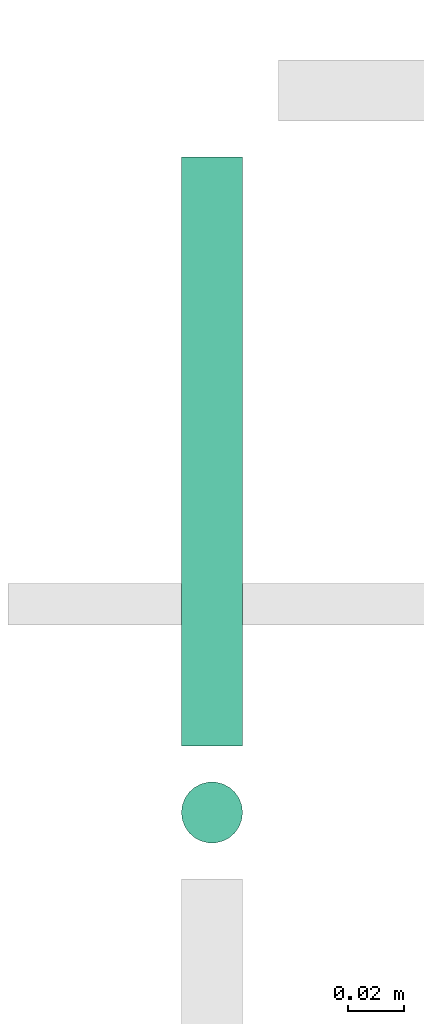
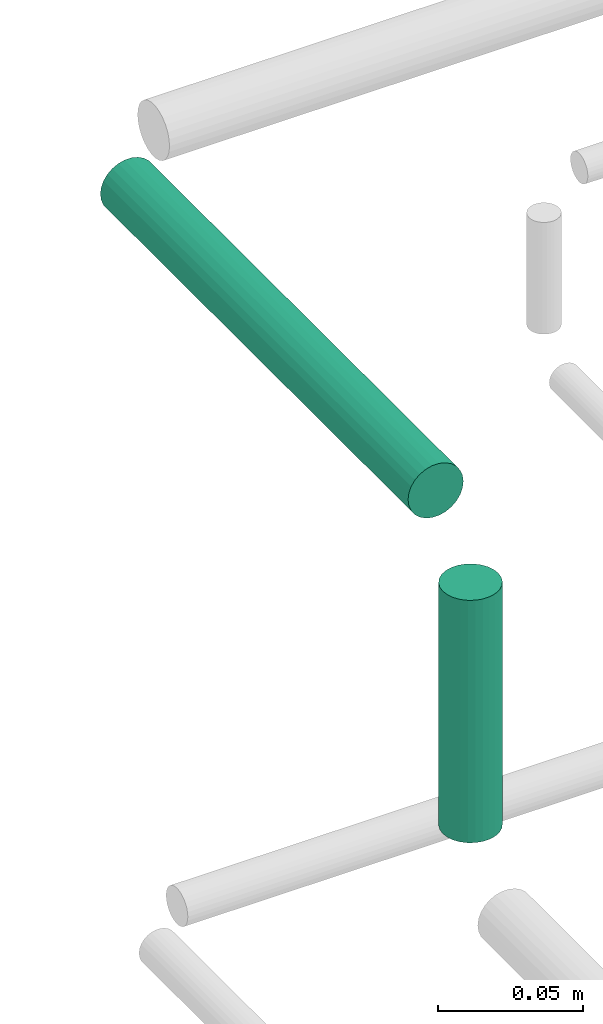
# One storey, part 126 of 331: 2 flow segments.
"""IFC2X3 building model written with IfcOpenShell, lengths in millimetres."""

from ifc_helpers import new_model, entity, si_unit, converted_unit, derived_unit, direction, frame, origin, origin_2d_with_axis, place, context, subcontext, project, spatial, circle, extrude, type_object, element, save


model = new_model("IFC2X3")

# Units and contexts
model_context = context("Model", 3, precision=0.01, world=origin(), true_north=direction((6.12303176911189e-17, 1.0)))
body_context = subcontext(model_context, "Body", "Model", "MODEL_VIEW")
ifc_project = project(units=[si_unit("LENGTHUNIT", "METRE", prefix="MILLI"), si_unit("AREAUNIT", "SQUARE_METRE"), si_unit("VOLUMEUNIT", "CUBIC_METRE"), converted_unit("PLANEANGLEUNIT", "DEGREE", entity("IfcRatioMeasure", 0.0174532925199433), si_unit("PLANEANGLEUNIT", "RADIAN"), dimensions=[0, 0, 0, 0, 0, 0, 0]), si_unit("MASSUNIT", "GRAM", prefix="KILO"), derived_unit("MASSDENSITYUNIT", [(si_unit("MASSUNIT", "GRAM", prefix="KILO"), 1), (si_unit("LENGTHUNIT", "METRE"), -3)]), derived_unit("MOMENTOFINERTIAUNIT", [(si_unit("LENGTHUNIT", "METRE"), 4)]), si_unit("TIMEUNIT", "SECOND"), si_unit("FREQUENCYUNIT", "HERTZ"), si_unit("THERMODYNAMICTEMPERATUREUNIT", "DEGREE_CELSIUS"), derived_unit("THERMALTRANSMITTANCEUNIT", [(si_unit("MASSUNIT", "GRAM", prefix="KILO"), 1), (si_unit("THERMODYNAMICTEMPERATUREUNIT", "KELVIN"), -1), (si_unit("TIMEUNIT", "SECOND"), -3)]), derived_unit("VOLUMETRICFLOWRATEUNIT", [(si_unit("LENGTHUNIT", "METRE"), 3), (si_unit("TIMEUNIT", "SECOND"), -1)]), derived_unit("MASSFLOWRATEUNIT", [(si_unit("MASSUNIT", "GRAM", prefix="KILO"), 1), (si_unit("TIMEUNIT", "SECOND"), -1)]), derived_unit("ROTATIONALFREQUENCYUNIT", [(si_unit("TIMEUNIT", "SECOND"), -1)]), si_unit("ELECTRICCURRENTUNIT", "AMPERE"), si_unit("ELECTRICVOLTAGEUNIT", "VOLT"), si_unit("POWERUNIT", "WATT"), si_unit("FORCEUNIT", "NEWTON", prefix="KILO"), si_unit("ILLUMINANCEUNIT", "LUX"), si_unit("LUMINOUSFLUXUNIT", "LUMEN"), si_unit("LUMINOUSINTENSITYUNIT", "CANDELA"), derived_unit("USERDEFINED", [(si_unit("MASSUNIT", "GRAM", prefix="KILO"), -1), (si_unit("LENGTHUNIT", "METRE"), -2), (si_unit("TIMEUNIT", "SECOND"), 3), (si_unit("LUMINOUSFLUXUNIT", "LUMEN"), 1)]), derived_unit("LINEARVELOCITYUNIT", [(si_unit("LENGTHUNIT", "METRE"), 1), (si_unit("TIMEUNIT", "SECOND"), -1)]), si_unit("PRESSUREUNIT", "PASCAL"), derived_unit("USERDEFINED", [(si_unit("LENGTHUNIT", "METRE"), -2), (si_unit("MASSUNIT", "GRAM", prefix="KILO"), 1), (si_unit("TIMEUNIT", "SECOND"), -2)]), derived_unit("LINEARFORCEUNIT", [(si_unit("MASSUNIT", "GRAM", prefix="KILO"), 1), (si_unit("LENGTHUNIT", "METRE"), 1), (si_unit("TIMEUNIT", "SECOND"), -2), (si_unit("LENGTHUNIT", "METRE"), -1)]), derived_unit("PLANARFORCEUNIT", [(si_unit("MASSUNIT", "GRAM", prefix="KILO"), 1), (si_unit("LENGTHUNIT", "METRE"), 1), (si_unit("TIMEUNIT", "SECOND"), -2), (si_unit("LENGTHUNIT", "METRE"), -2)])], contexts=[model_context])

# Site, building, storey
site_placement = place(None, frame((0.0, -0.00077364408347762, 0.0)))
site = spatial("IfcSite", under=ifc_project, at=site_placement, CompositionType="ELEMENT")
building_placement = place(site_placement, origin())
building = spatial("IfcBuilding", under=site, at=building_placement, CompositionType="ELEMENT")
storey_placement = place(building_placement, origin())
storey = spatial("IfcBuildingStorey", under=building, at=storey_placement, CompositionType="ELEMENT", Elevation=0.0)

# Flow segments
pipe_segment_type = type_object("IfcPipeSegmentType", PredefinedType="NOTDEFINED")
flow_segment_1_placement = place(storey_placement, frame((18639.9437531701, 9224.0, 18692.4047277641)))
element("IfcFlowSegment", 1, at=flow_segment_1_placement, inside=storey, type_object=pipe_segment_type, context=body_context, shape_type="SweptSolid", body=[
    extrude(circle(Radius=11.0, at=origin_2d_with_axis()), frame((12.5952722359264, 0.0, 12.5952722359156), z_axis=(0.0, 1.0, 0.0), x_axis=(1.0, 0.0, 0.0)), (0.0, 0.0, 1.0), 212.000000000004),
])
flow_segment_2_placement = place(storey_placement, frame((18639.9437531701, 9187.40472776839, 18579.0)))
element("IfcFlowSegment", 2, at=flow_segment_2_placement, inside=storey, type_object=pipe_segment_type, context=body_context, shape_type="SweptSolid", body=[
    extrude(circle(Radius=11.0, at=origin_2d_with_axis()), frame((12.5952722359156, 12.5952722359156, 0.0)), (0.0, 0.0, 1.0), 102.000000000102),
])

save(model, "model.ifc")
